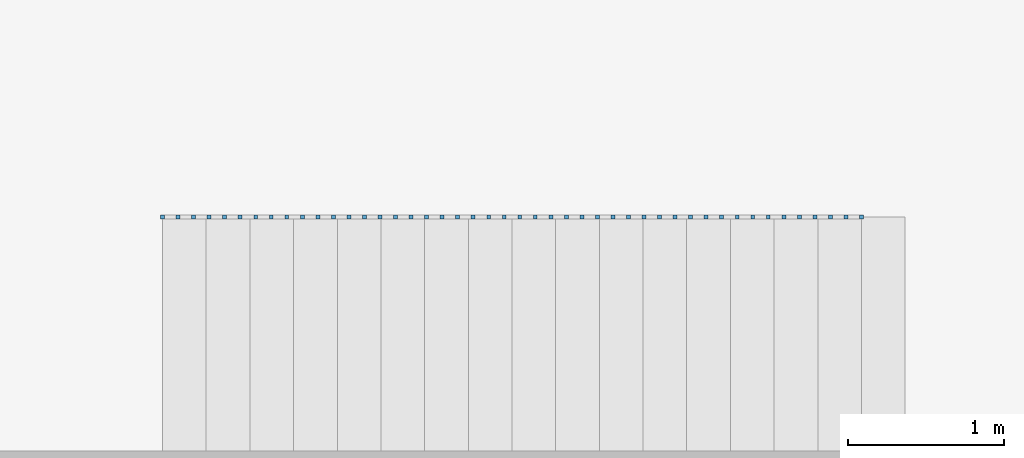
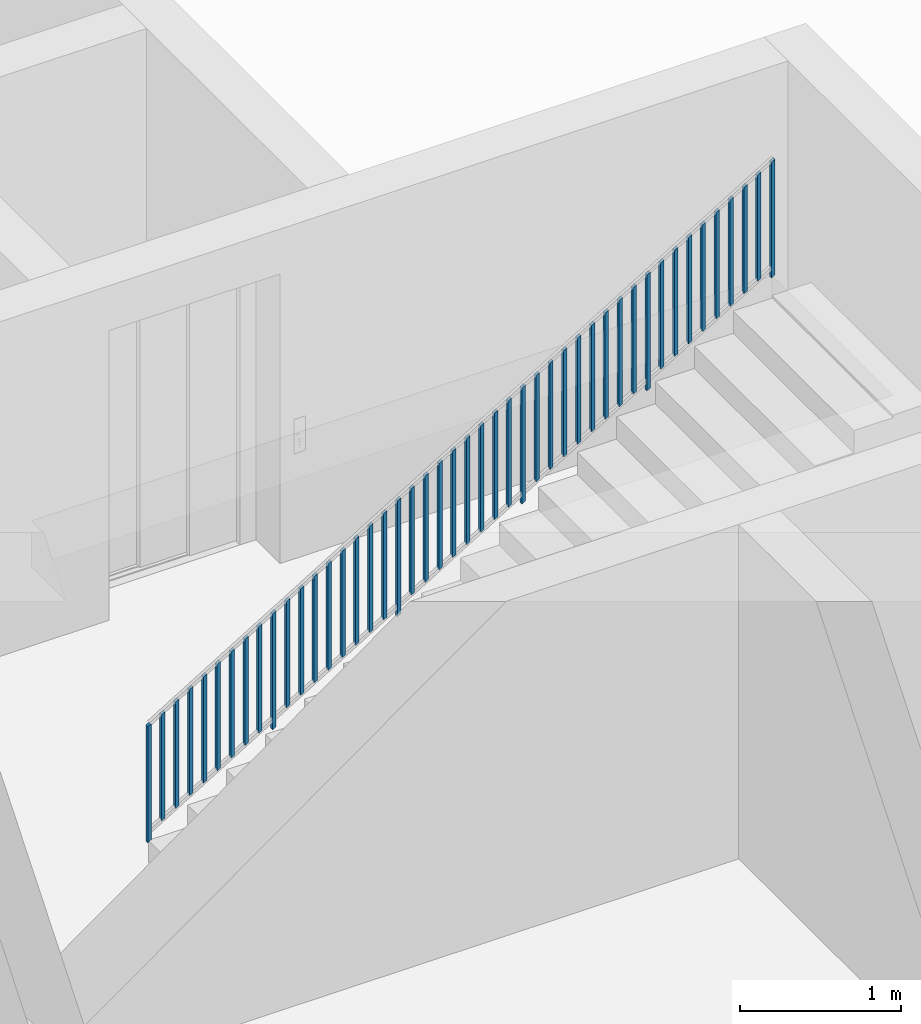
# One storey, part 6 of 6: 46 building element parts, 1 element without a shape of its own.
"""IFC4 building model written with IfcOpenShell, lengths in metres."""

from ifc_helpers import new_model, entity, si_unit, converted_unit, derived_unit, direction, frame, origin_with_axes, place, context, subcontext, project, spatial, polygons, material, type_object, element, aggregate, save


model = new_model("IFC4")

# Units and contexts
model_context = context("Model", 3, precision=1e-05, world=origin_with_axes(), true_north=direction((0.0, 1.0)))
body_context = subcontext(model_context, "Body", "Model", "MODEL_VIEW")
ifc_project = project(units=[si_unit("LENGTHUNIT", "METRE"), si_unit("AREAUNIT", "SQUARE_METRE"), si_unit("VOLUMEUNIT", "CUBIC_METRE"), converted_unit("PLANEANGLEUNIT", "DEGREE", entity("IfcPlaneAngleMeasure", 0.0174532925199), si_unit("PLANEANGLEUNIT", "RADIAN"), dimensions=[0, 0, 0, 0, 0, 0, 0]), converted_unit("TIMEUNIT", "Year", entity("IfcTimeMeasure", 31556926.0), si_unit("TIMEUNIT", "SECOND"), dimensions=[0, 0, 1, 0, 0, 0, 0]), si_unit("MASSUNIT", "GRAM", prefix="KILO"), si_unit("THERMODYNAMICTEMPERATUREUNIT", "DEGREE_CELSIUS"), si_unit("LUMINOUSINTENSITYUNIT", "LUMEN"), si_unit("ENERGYUNIT", "JOULE", prefix="MEGA"), derived_unit("THERMALCONDUCTANCEUNIT", [(si_unit("POWERUNIT", "WATT"), 1), (si_unit("LENGTHUNIT", "METRE"), -1), (si_unit("THERMODYNAMICTEMPERATUREUNIT", "KELVIN"), -1)]), derived_unit("SPECIFICHEATCAPACITYUNIT", [(si_unit("ENERGYUNIT", "JOULE"), 1), (si_unit("MASSUNIT", "GRAM", prefix="KILO"), -1), (si_unit("THERMODYNAMICTEMPERATUREUNIT", "KELVIN"), -1)]), derived_unit("MASSDENSITYUNIT", [(si_unit("MASSUNIT", "GRAM", prefix="KILO"), 1), (si_unit("VOLUMEUNIT", "CUBIC_METRE"), -1)])], contexts=[model_context])

# Site, building, storey, space
site_placement = place(None, origin_with_axes())
site = spatial("IfcSite", under=ifc_project, at=site_placement, CompositionType="ELEMENT")
building_placement = place(site_placement, origin_with_axes())
building = spatial("IfcBuilding", under=site, at=building_placement, CompositionType="ELEMENT")
storey_placement = place(building_placement, frame((0.0, 0.0, -2.89), z_axis=(0.0, 0.0, 1.0), x_axis=(1.0, 0.0, 0.0)))
storey = spatial("IfcBuildingStorey", under=building, at=storey_placement, Name="-1. Geschoss", CompositionType="ELEMENT", Elevation=-2.89)
space_placement = place(storey_placement, frame((-4.9421993804, -2.52881223104, 0.0), z_axis=(0.0, 0.0, 1.0), x_axis=(1.0, 0.0, 0.0)))
space = spatial("IfcSpace", under=storey, at=space_placement, CompositionType="ELEMENT", PredefinedType="INTERNAL")

# Railing, building element parts
railing_type = type_object("IfcRailingType", PredefinedType="NOTDEFINED")
railing_placement = place(space_placement, frame((1.5, 1.5, 0.17), z_axis=(0.0, 0.0, 1.0), x_axis=(1.0, 0.0, 0.0)))
railing = element("IfcRailing", 1, at=railing_placement, inside=space, type_object=railing_type, PredefinedType="NOTDEFINED")
ifc_material = material()
building_element_part_1_placement = place(railing_placement, origin_with_axes())
building_element_part_1 = element("IfcBuildingElementPart", 2, at=building_element_part_1_placement, material=ifc_material, PredefinedType="NOTDEFINED", context=body_context, shape_type="Tessellation", body=[
    polygons([(0.0125, -0.0125, 0.00758928571429), (0.0125, 0.0125, 0.00758928571429), (0.0125, 0.0125, 0.887589285714), (0.0125, -0.0125, 0.887589285714), (-0.0125, -0.0125, -0.00758928571429), (-0.0125, 0.0125, -0.00758928571429), (-0.0125, 0.0125, 0.872410714286), (-0.0125, -0.0125, 0.872410714286)], [[[1, 2, 3, 4]], [[1, 5, 6, 2]], [[2, 6, 7, 3]], [[4, 3, 7, 8]], [[5, 1, 4, 8]], [[6, 5, 8, 7]]], closed=True),
])
building_element_part_2_placement = place(railing_placement, origin_with_axes())
building_element_part_2 = element("IfcBuildingElementPart", 3, at=building_element_part_2_placement, material=ifc_material, PredefinedType="NOTDEFINED", context=body_context, shape_type="Tessellation", body=[
    polygons([(4.4925, -0.0125, 2.72758928571), (4.4925, 0.0125, 2.72758928571), (4.4925, 0.0125, 3.60758928571), (4.4925, -0.0125, 3.60758928571), (4.4675, -0.0125, 2.71241071429), (4.4675, 0.0125, 2.71241071429), (4.4675, 0.0125, 3.59241071429), (4.4675, -0.0125, 3.59241071429)], [[[1, 2, 3, 4]], [[1, 5, 6, 2]], [[2, 6, 7, 3]], [[4, 3, 7, 8]], [[5, 1, 4, 8]], [[6, 5, 8, 7]]], closed=True),
])
building_element_part_3_placement = place(railing_placement, origin_with_axes())
building_element_part_3 = element("IfcBuildingElementPart", 4, at=building_element_part_3_placement, material=ifc_material, PredefinedType="NOTDEFINED", context=body_context, shape_type="Tessellation", body=[
    polygons([(0.112055555556, -0.0125, 0.138033730159), (0.112055555556, 0.0125, 0.138033730159), (0.112055555556, 0.0125, 0.945533730159), (0.112055555556, -0.0125, 0.945533730159), (0.0870555555556, -0.0125, 0.12285515873), (0.0870555555556, 0.0125, 0.12285515873), (0.0870555555556, 0.0125, 0.93035515873), (0.0870555555556, -0.0125, 0.93035515873)], [[[1, 2, 3, 4]], [[1, 5, 6, 2]], [[2, 6, 7, 3]], [[4, 3, 7, 8]], [[5, 1, 4, 8]], [[6, 5, 8, 7]]], closed=True),
])
building_element_part_4_placement = place(railing_placement, origin_with_axes())
building_element_part_4 = element("IfcBuildingElementPart", 5, at=building_element_part_4_placement, material=ifc_material, PredefinedType="NOTDEFINED", context=body_context, shape_type="Tessellation", body=[
    polygons([(0.211611111111, -0.0125, 0.198478174603), (0.211611111111, 0.0125, 0.198478174603), (0.211611111111, 0.0125, 1.0059781746), (0.211611111111, -0.0125, 1.0059781746), (0.186611111111, -0.0125, 0.183299603175), (0.186611111111, 0.0125, 0.183299603175), (0.186611111111, 0.0125, 0.990799603175), (0.186611111111, -0.0125, 0.990799603175)], [[[1, 2, 3, 4]], [[1, 5, 6, 2]], [[2, 6, 7, 3]], [[4, 3, 7, 8]], [[5, 1, 4, 8]], [[6, 5, 8, 7]]], closed=True),
])
building_element_part_5_placement = place(railing_placement, origin_with_axes())
building_element_part_5 = element("IfcBuildingElementPart", 6, at=building_element_part_5_placement, material=ifc_material, PredefinedType="NOTDEFINED", context=body_context, shape_type="Tessellation", body=[
    polygons([(0.311166666667, -0.0125, 0.258922619048), (0.311166666667, 0.0125, 0.258922619048), (0.311166666667, 0.0125, 1.06642261905), (0.311166666667, -0.0125, 1.06642261905), (0.286166666667, -0.0125, 0.243744047619), (0.286166666667, 0.0125, 0.243744047619), (0.286166666667, 0.0125, 1.05124404762), (0.286166666667, -0.0125, 1.05124404762)], [[[1, 2, 3, 4]], [[1, 5, 6, 2]], [[2, 6, 7, 3]], [[4, 3, 7, 8]], [[5, 1, 4, 8]], [[6, 5, 8, 7]]], closed=True),
])
building_element_part_6_placement = place(railing_placement, origin_with_axes())
building_element_part_6 = element("IfcBuildingElementPart", 7, at=building_element_part_6_placement, material=ifc_material, PredefinedType="NOTDEFINED", context=body_context, shape_type="Tessellation", body=[
    polygons([(0.410722222222, -0.0125, 0.319367063492), (0.410722222222, 0.0125, 0.319367063492), (0.410722222222, 0.0125, 1.12686706349), (0.410722222222, -0.0125, 1.12686706349), (0.385722222222, -0.0125, 0.304188492063), (0.385722222222, 0.0125, 0.304188492063), (0.385722222222, 0.0125, 1.11168849206), (0.385722222222, -0.0125, 1.11168849206)], [[[1, 2, 3, 4]], [[1, 5, 6, 2]], [[2, 6, 7, 3]], [[4, 3, 7, 8]], [[5, 1, 4, 8]], [[6, 5, 8, 7]]], closed=True),
])
building_element_part_7_placement = place(railing_placement, origin_with_axes())
building_element_part_7 = element("IfcBuildingElementPart", 8, at=building_element_part_7_placement, material=ifc_material, PredefinedType="NOTDEFINED", context=body_context, shape_type="Tessellation", body=[
    polygons([(0.510277777778, -0.0125, 0.379811507937), (0.510277777778, 0.0125, 0.379811507937), (0.510277777778, 0.0125, 1.18731150794), (0.510277777778, -0.0125, 1.18731150794), (0.485277777778, -0.0125, 0.364632936508), (0.485277777778, 0.0125, 0.364632936508), (0.485277777778, 0.0125, 1.17213293651), (0.485277777778, -0.0125, 1.17213293651)], [[[1, 2, 3, 4]], [[1, 5, 6, 2]], [[2, 6, 7, 3]], [[4, 3, 7, 8]], [[5, 1, 4, 8]], [[6, 5, 8, 7]]], closed=True),
])
building_element_part_8_placement = place(railing_placement, origin_with_axes())
building_element_part_8 = element("IfcBuildingElementPart", 9, at=building_element_part_8_placement, material=ifc_material, PredefinedType="NOTDEFINED", context=body_context, shape_type="Tessellation", body=[
    polygons([(0.609833333333, -0.0125, 0.440255952381), (0.609833333333, 0.0125, 0.440255952381), (0.609833333333, 0.0125, 1.24775595238), (0.609833333333, -0.0125, 1.24775595238), (0.584833333333, -0.0125, 0.425077380952), (0.584833333333, 0.0125, 0.425077380952), (0.584833333333, 0.0125, 1.23257738095), (0.584833333333, -0.0125, 1.23257738095)], [[[1, 2, 3, 4]], [[1, 5, 6, 2]], [[2, 6, 7, 3]], [[4, 3, 7, 8]], [[5, 1, 4, 8]], [[6, 5, 8, 7]]], closed=True),
])
building_element_part_9_placement = place(railing_placement, origin_with_axes())
building_element_part_9 = element("IfcBuildingElementPart", 10, at=building_element_part_9_placement, material=ifc_material, PredefinedType="NOTDEFINED", context=body_context, shape_type="Tessellation", body=[
    polygons([(0.709388888889, -0.0125, 0.500700396825), (0.709388888889, 0.0125, 0.500700396825), (0.709388888889, 0.0125, 1.30820039683), (0.709388888889, -0.0125, 1.30820039683), (0.684388888889, -0.0125, 0.485521825397), (0.684388888889, 0.0125, 0.485521825397), (0.684388888889, 0.0125, 1.2930218254), (0.684388888889, -0.0125, 1.2930218254)], [[[1, 2, 3, 4]], [[1, 5, 6, 2]], [[2, 6, 7, 3]], [[4, 3, 7, 8]], [[5, 1, 4, 8]], [[6, 5, 8, 7]]], closed=True),
])
building_element_part_10_placement = place(railing_placement, origin_with_axes())
building_element_part_10 = element("IfcBuildingElementPart", 11, at=building_element_part_10_placement, material=ifc_material, PredefinedType="NOTDEFINED", context=body_context, shape_type="Tessellation", body=[
    polygons([(0.808944444444, -0.0125, 0.56114484127), (0.808944444444, 0.0125, 0.56114484127), (0.808944444444, 0.0125, 1.36864484127), (0.808944444444, -0.0125, 1.36864484127), (0.783944444444, -0.0125, 0.545966269841), (0.783944444444, 0.0125, 0.545966269841), (0.783944444444, 0.0125, 1.35346626984), (0.783944444444, -0.0125, 1.35346626984)], [[[1, 2, 3, 4]], [[1, 5, 6, 2]], [[2, 6, 7, 3]], [[4, 3, 7, 8]], [[5, 1, 4, 8]], [[6, 5, 8, 7]]], closed=True),
])
building_element_part_11_placement = place(railing_placement, origin_with_axes())
building_element_part_11 = element("IfcBuildingElementPart", 12, at=building_element_part_11_placement, material=ifc_material, PredefinedType="NOTDEFINED", context=body_context, shape_type="Tessellation", body=[
    polygons([(0.9085, -0.0125, 0.551589285714), (0.9085, 0.0125, 0.551589285714), (0.9085, 0.0125, 1.43158928571), (0.9085, -0.0125, 1.43158928571), (0.8835, -0.0125, 0.536410714286), (0.8835, 0.0125, 0.536410714286), (0.8835, 0.0125, 1.41641071429), (0.8835, -0.0125, 1.41641071429)], [[[1, 2, 3, 4]], [[1, 5, 6, 2]], [[2, 6, 7, 3]], [[4, 3, 7, 8]], [[5, 1, 4, 8]], [[6, 5, 8, 7]]], closed=True),
])
building_element_part_12_placement = place(railing_placement, origin_with_axes())
building_element_part_12 = element("IfcBuildingElementPart", 13, at=building_element_part_12_placement, material=ifc_material, PredefinedType="NOTDEFINED", context=body_context, shape_type="Tessellation", body=[
    polygons([(1.00805555556, -0.0125, 0.682033730159), (1.00805555556, 0.0125, 0.682033730159), (1.00805555556, 0.0125, 1.48953373016), (1.00805555556, -0.0125, 1.48953373016), (0.983055555556, -0.0125, 0.66685515873), (0.983055555556, 0.0125, 0.66685515873), (0.983055555556, 0.0125, 1.47435515873), (0.983055555556, -0.0125, 1.47435515873)], [[[1, 2, 3, 4]], [[1, 5, 6, 2]], [[2, 6, 7, 3]], [[4, 3, 7, 8]], [[5, 1, 4, 8]], [[6, 5, 8, 7]]], closed=True),
])
building_element_part_13_placement = place(railing_placement, origin_with_axes())
building_element_part_13 = element("IfcBuildingElementPart", 14, at=building_element_part_13_placement, material=ifc_material, PredefinedType="NOTDEFINED", context=body_context, shape_type="Tessellation", body=[
    polygons([(1.10761111111, -0.0125, 0.742478174603), (1.10761111111, 0.0125, 0.742478174603), (1.10761111111, 0.0125, 1.5499781746), (1.10761111111, -0.0125, 1.5499781746), (1.08261111111, -0.0125, 0.727299603175), (1.08261111111, 0.0125, 0.727299603175), (1.08261111111, 0.0125, 1.53479960317), (1.08261111111, -0.0125, 1.53479960317)], [[[1, 2, 3, 4]], [[1, 5, 6, 2]], [[2, 6, 7, 3]], [[4, 3, 7, 8]], [[5, 1, 4, 8]], [[6, 5, 8, 7]]], closed=True),
])
building_element_part_14_placement = place(railing_placement, origin_with_axes())
building_element_part_14 = element("IfcBuildingElementPart", 15, at=building_element_part_14_placement, material=ifc_material, PredefinedType="NOTDEFINED", context=body_context, shape_type="Tessellation", body=[
    polygons([(1.20716666667, -0.0125, 0.802922619048), (1.20716666667, 0.0125, 0.802922619048), (1.20716666667, 0.0125, 1.61042261905), (1.20716666667, -0.0125, 1.61042261905), (1.18216666667, -0.0125, 0.787744047619), (1.18216666667, 0.0125, 0.787744047619), (1.18216666667, 0.0125, 1.59524404762), (1.18216666667, -0.0125, 1.59524404762)], [[[1, 2, 3, 4]], [[1, 5, 6, 2]], [[2, 6, 7, 3]], [[4, 3, 7, 8]], [[5, 1, 4, 8]], [[6, 5, 8, 7]]], closed=True),
])
building_element_part_15_placement = place(railing_placement, origin_with_axes())
building_element_part_15 = element("IfcBuildingElementPart", 16, at=building_element_part_15_placement, material=ifc_material, PredefinedType="NOTDEFINED", context=body_context, shape_type="Tessellation", body=[
    polygons([(1.30672222222, -0.0125, 0.863367063492), (1.30672222222, 0.0125, 0.863367063492), (1.30672222222, 0.0125, 1.67086706349), (1.30672222222, -0.0125, 1.67086706349), (1.28172222222, -0.0125, 0.848188492063), (1.28172222222, 0.0125, 0.848188492063), (1.28172222222, 0.0125, 1.65568849206), (1.28172222222, -0.0125, 1.65568849206)], [[[1, 2, 3, 4]], [[1, 5, 6, 2]], [[2, 6, 7, 3]], [[4, 3, 7, 8]], [[5, 1, 4, 8]], [[6, 5, 8, 7]]], closed=True),
])
building_element_part_16_placement = place(railing_placement, origin_with_axes())
building_element_part_16 = element("IfcBuildingElementPart", 17, at=building_element_part_16_placement, material=ifc_material, PredefinedType="NOTDEFINED", context=body_context, shape_type="Tessellation", body=[
    polygons([(1.40627777778, -0.0125, 0.923811507937), (1.40627777778, 0.0125, 0.923811507937), (1.40627777778, 0.0125, 1.73131150794), (1.40627777778, -0.0125, 1.73131150794), (1.38127777778, -0.0125, 0.908632936508), (1.38127777778, 0.0125, 0.908632936508), (1.38127777778, 0.0125, 1.71613293651), (1.38127777778, -0.0125, 1.71613293651)], [[[1, 2, 3, 4]], [[1, 5, 6, 2]], [[2, 6, 7, 3]], [[4, 3, 7, 8]], [[5, 1, 4, 8]], [[6, 5, 8, 7]]], closed=True),
])
building_element_part_17_placement = place(railing_placement, origin_with_axes())
building_element_part_17 = element("IfcBuildingElementPart", 18, at=building_element_part_17_placement, material=ifc_material, PredefinedType="NOTDEFINED", context=body_context, shape_type="Tessellation", body=[
    polygons([(1.50583333333, -0.0125, 0.984255952381), (1.50583333333, 0.0125, 0.984255952381), (1.50583333333, 0.0125, 1.79175595238), (1.50583333333, -0.0125, 1.79175595238), (1.48083333333, -0.0125, 0.969077380952), (1.48083333333, 0.0125, 0.969077380952), (1.48083333333, 0.0125, 1.77657738095), (1.48083333333, -0.0125, 1.77657738095)], [[[1, 2, 3, 4]], [[1, 5, 6, 2]], [[2, 6, 7, 3]], [[4, 3, 7, 8]], [[5, 1, 4, 8]], [[6, 5, 8, 7]]], closed=True),
])
building_element_part_18_placement = place(railing_placement, origin_with_axes())
building_element_part_18 = element("IfcBuildingElementPart", 19, at=building_element_part_18_placement, material=ifc_material, PredefinedType="NOTDEFINED", context=body_context, shape_type="Tessellation", body=[
    polygons([(1.60538888889, -0.0125, 1.04470039683), (1.60538888889, 0.0125, 1.04470039683), (1.60538888889, 0.0125, 1.85220039683), (1.60538888889, -0.0125, 1.85220039683), (1.58038888889, -0.0125, 1.0295218254), (1.58038888889, 0.0125, 1.0295218254), (1.58038888889, 0.0125, 1.8370218254), (1.58038888889, -0.0125, 1.8370218254)], [[[1, 2, 3, 4]], [[1, 5, 6, 2]], [[2, 6, 7, 3]], [[4, 3, 7, 8]], [[5, 1, 4, 8]], [[6, 5, 8, 7]]], closed=True),
])
building_element_part_19_placement = place(railing_placement, origin_with_axes())
building_element_part_19 = element("IfcBuildingElementPart", 20, at=building_element_part_19_placement, material=ifc_material, PredefinedType="NOTDEFINED", context=body_context, shape_type="Tessellation", body=[
    polygons([(1.70494444444, -0.0125, 1.10514484127), (1.70494444444, 0.0125, 1.10514484127), (1.70494444444, 0.0125, 1.91264484127), (1.70494444444, -0.0125, 1.91264484127), (1.67994444444, -0.0125, 1.08996626984), (1.67994444444, 0.0125, 1.08996626984), (1.67994444444, 0.0125, 1.89746626984), (1.67994444444, -0.0125, 1.89746626984)], [[[1, 2, 3, 4]], [[1, 5, 6, 2]], [[2, 6, 7, 3]], [[4, 3, 7, 8]], [[5, 1, 4, 8]], [[6, 5, 8, 7]]], closed=True),
])
building_element_part_20_placement = place(railing_placement, origin_with_axes())
building_element_part_20 = element("IfcBuildingElementPart", 21, at=building_element_part_20_placement, material=ifc_material, PredefinedType="NOTDEFINED", context=body_context, shape_type="Tessellation", body=[
    polygons([(1.8045, -0.0125, 1.09558928571), (1.8045, 0.0125, 1.09558928571), (1.8045, 0.0125, 1.97558928571), (1.8045, -0.0125, 1.97558928571), (1.7795, -0.0125, 1.08041071429), (1.7795, 0.0125, 1.08041071429), (1.7795, 0.0125, 1.96041071429), (1.7795, -0.0125, 1.96041071429)], [[[1, 2, 3, 4]], [[1, 5, 6, 2]], [[2, 6, 7, 3]], [[4, 3, 7, 8]], [[5, 1, 4, 8]], [[6, 5, 8, 7]]], closed=True),
])
building_element_part_21_placement = place(railing_placement, origin_with_axes())
building_element_part_21 = element("IfcBuildingElementPart", 22, at=building_element_part_21_placement, material=ifc_material, PredefinedType="NOTDEFINED", context=body_context, shape_type="Tessellation", body=[
    polygons([(1.90405555556, -0.0125, 1.22603373016), (1.90405555556, 0.0125, 1.22603373016), (1.90405555556, 0.0125, 2.03353373016), (1.90405555556, -0.0125, 2.03353373016), (1.87905555556, -0.0125, 1.21085515873), (1.87905555556, 0.0125, 1.21085515873), (1.87905555556, 0.0125, 2.01835515873), (1.87905555556, -0.0125, 2.01835515873)], [[[1, 2, 3, 4]], [[1, 5, 6, 2]], [[2, 6, 7, 3]], [[4, 3, 7, 8]], [[5, 1, 4, 8]], [[6, 5, 8, 7]]], closed=True),
])
building_element_part_22_placement = place(railing_placement, origin_with_axes())
building_element_part_22 = element("IfcBuildingElementPart", 23, at=building_element_part_22_placement, material=ifc_material, PredefinedType="NOTDEFINED", context=body_context, shape_type="Tessellation", body=[
    polygons([(2.00361111111, -0.0125, 1.2864781746), (2.00361111111, 0.0125, 1.2864781746), (2.00361111111, 0.0125, 2.0939781746), (2.00361111111, -0.0125, 2.0939781746), (1.97861111111, -0.0125, 1.27129960317), (1.97861111111, 0.0125, 1.27129960317), (1.97861111111, 0.0125, 2.07879960317), (1.97861111111, -0.0125, 2.07879960317)], [[[1, 2, 3, 4]], [[1, 5, 6, 2]], [[2, 6, 7, 3]], [[4, 3, 7, 8]], [[5, 1, 4, 8]], [[6, 5, 8, 7]]], closed=True),
])
building_element_part_23_placement = place(railing_placement, origin_with_axes())
building_element_part_23 = element("IfcBuildingElementPart", 24, at=building_element_part_23_placement, material=ifc_material, PredefinedType="NOTDEFINED", context=body_context, shape_type="Tessellation", body=[
    polygons([(2.10316666667, -0.0125, 1.34692261905), (2.10316666667, 0.0125, 1.34692261905), (2.10316666667, 0.0125, 2.15442261905), (2.10316666667, -0.0125, 2.15442261905), (2.07816666667, -0.0125, 1.33174404762), (2.07816666667, 0.0125, 1.33174404762), (2.07816666667, 0.0125, 2.13924404762), (2.07816666667, -0.0125, 2.13924404762)], [[[1, 2, 3, 4]], [[1, 5, 6, 2]], [[2, 6, 7, 3]], [[4, 3, 7, 8]], [[5, 1, 4, 8]], [[6, 5, 8, 7]]], closed=True),
])
building_element_part_24_placement = place(railing_placement, origin_with_axes())
building_element_part_24 = element("IfcBuildingElementPart", 25, at=building_element_part_24_placement, material=ifc_material, PredefinedType="NOTDEFINED", context=body_context, shape_type="Tessellation", body=[
    polygons([(2.20272222222, -0.0125, 1.40736706349), (2.20272222222, 0.0125, 1.40736706349), (2.20272222222, 0.0125, 2.21486706349), (2.20272222222, -0.0125, 2.21486706349), (2.17772222222, -0.0125, 1.39218849206), (2.17772222222, 0.0125, 1.39218849206), (2.17772222222, 0.0125, 2.19968849206), (2.17772222222, -0.0125, 2.19968849206)], [[[1, 2, 3, 4]], [[1, 5, 6, 2]], [[2, 6, 7, 3]], [[4, 3, 7, 8]], [[5, 1, 4, 8]], [[6, 5, 8, 7]]], closed=True),
])
building_element_part_25_placement = place(railing_placement, origin_with_axes())
building_element_part_25 = element("IfcBuildingElementPart", 26, at=building_element_part_25_placement, material=ifc_material, PredefinedType="NOTDEFINED", context=body_context, shape_type="Tessellation", body=[
    polygons([(2.30227777778, -0.0125, 1.46781150794), (2.30227777778, 0.0125, 1.46781150794), (2.30227777778, 0.0125, 2.27531150794), (2.30227777778, -0.0125, 2.27531150794), (2.27727777778, -0.0125, 1.45263293651), (2.27727777778, 0.0125, 1.45263293651), (2.27727777778, 0.0125, 2.26013293651), (2.27727777778, -0.0125, 2.26013293651)], [[[1, 2, 3, 4]], [[1, 5, 6, 2]], [[2, 6, 7, 3]], [[4, 3, 7, 8]], [[5, 1, 4, 8]], [[6, 5, 8, 7]]], closed=True),
])
building_element_part_26_placement = place(railing_placement, origin_with_axes())
building_element_part_26 = element("IfcBuildingElementPart", 27, at=building_element_part_26_placement, material=ifc_material, PredefinedType="NOTDEFINED", context=body_context, shape_type="Tessellation", body=[
    polygons([(2.40183333333, -0.0125, 1.52825595238), (2.40183333333, 0.0125, 1.52825595238), (2.40183333333, 0.0125, 2.33575595238), (2.40183333333, -0.0125, 2.33575595238), (2.37683333333, -0.0125, 1.51307738095), (2.37683333333, 0.0125, 1.51307738095), (2.37683333333, 0.0125, 2.32057738095), (2.37683333333, -0.0125, 2.32057738095)], [[[1, 2, 3, 4]], [[1, 5, 6, 2]], [[2, 6, 7, 3]], [[4, 3, 7, 8]], [[5, 1, 4, 8]], [[6, 5, 8, 7]]], closed=True),
])
building_element_part_27_placement = place(railing_placement, origin_with_axes())
building_element_part_27 = element("IfcBuildingElementPart", 28, at=building_element_part_27_placement, material=ifc_material, PredefinedType="NOTDEFINED", context=body_context, shape_type="Tessellation", body=[
    polygons([(2.50138888889, -0.0125, 1.58870039683), (2.50138888889, 0.0125, 1.58870039683), (2.50138888889, 0.0125, 2.39620039683), (2.50138888889, -0.0125, 2.39620039683), (2.47638888889, -0.0125, 1.5735218254), (2.47638888889, 0.0125, 1.5735218254), (2.47638888889, 0.0125, 2.3810218254), (2.47638888889, -0.0125, 2.3810218254)], [[[1, 2, 3, 4]], [[1, 5, 6, 2]], [[2, 6, 7, 3]], [[4, 3, 7, 8]], [[5, 1, 4, 8]], [[6, 5, 8, 7]]], closed=True),
])
building_element_part_28_placement = place(railing_placement, origin_with_axes())
building_element_part_28 = element("IfcBuildingElementPart", 29, at=building_element_part_28_placement, material=ifc_material, PredefinedType="NOTDEFINED", context=body_context, shape_type="Tessellation", body=[
    polygons([(2.60094444444, -0.0125, 1.64914484127), (2.60094444444, 0.0125, 1.64914484127), (2.60094444444, 0.0125, 2.45664484127), (2.60094444444, -0.0125, 2.45664484127), (2.57594444444, -0.0125, 1.63396626984), (2.57594444444, 0.0125, 1.63396626984), (2.57594444444, 0.0125, 2.44146626984), (2.57594444444, -0.0125, 2.44146626984)], [[[1, 2, 3, 4]], [[1, 5, 6, 2]], [[2, 6, 7, 3]], [[4, 3, 7, 8]], [[5, 1, 4, 8]], [[6, 5, 8, 7]]], closed=True),
])
building_element_part_29_placement = place(railing_placement, origin_with_axes())
building_element_part_29 = element("IfcBuildingElementPart", 30, at=building_element_part_29_placement, material=ifc_material, PredefinedType="NOTDEFINED", context=body_context, shape_type="Tessellation", body=[
    polygons([(2.7005, -0.0125, 1.63958928571), (2.7005, 0.0125, 1.63958928571), (2.7005, 0.0125, 2.51958928571), (2.7005, -0.0125, 2.51958928571), (2.6755, -0.0125, 1.62441071429), (2.6755, 0.0125, 1.62441071429), (2.6755, 0.0125, 2.50441071429), (2.6755, -0.0125, 2.50441071429)], [[[1, 2, 3, 4]], [[1, 5, 6, 2]], [[2, 6, 7, 3]], [[4, 3, 7, 8]], [[5, 1, 4, 8]], [[6, 5, 8, 7]]], closed=True),
])
building_element_part_30_placement = place(railing_placement, origin_with_axes())
building_element_part_30 = element("IfcBuildingElementPart", 31, at=building_element_part_30_placement, material=ifc_material, PredefinedType="NOTDEFINED", context=body_context, shape_type="Tessellation", body=[
    polygons([(2.80005555556, -0.0125, 1.77003373016), (2.80005555556, 0.0125, 1.77003373016), (2.80005555556, 0.0125, 2.57753373016), (2.80005555556, -0.0125, 2.57753373016), (2.77505555556, -0.0125, 1.75485515873), (2.77505555556, 0.0125, 1.75485515873), (2.77505555556, 0.0125, 2.56235515873), (2.77505555556, -0.0125, 2.56235515873)], [[[1, 2, 3, 4]], [[1, 5, 6, 2]], [[2, 6, 7, 3]], [[4, 3, 7, 8]], [[5, 1, 4, 8]], [[6, 5, 8, 7]]], closed=True),
])
building_element_part_31_placement = place(railing_placement, origin_with_axes())
building_element_part_31 = element("IfcBuildingElementPart", 32, at=building_element_part_31_placement, material=ifc_material, PredefinedType="NOTDEFINED", context=body_context, shape_type="Tessellation", body=[
    polygons([(2.89961111111, -0.0125, 1.8304781746), (2.89961111111, 0.0125, 1.8304781746), (2.89961111111, 0.0125, 2.6379781746), (2.89961111111, -0.0125, 2.6379781746), (2.87461111111, -0.0125, 1.81529960317), (2.87461111111, 0.0125, 1.81529960317), (2.87461111111, 0.0125, 2.62279960317), (2.87461111111, -0.0125, 2.62279960317)], [[[1, 2, 3, 4]], [[1, 5, 6, 2]], [[2, 6, 7, 3]], [[4, 3, 7, 8]], [[5, 1, 4, 8]], [[6, 5, 8, 7]]], closed=True),
])
building_element_part_32_placement = place(railing_placement, origin_with_axes())
building_element_part_32 = element("IfcBuildingElementPart", 33, at=building_element_part_32_placement, material=ifc_material, PredefinedType="NOTDEFINED", context=body_context, shape_type="Tessellation", body=[
    polygons([(2.99916666667, -0.0125, 1.89092261905), (2.99916666667, 0.0125, 1.89092261905), (2.99916666667, 0.0125, 2.69842261905), (2.99916666667, -0.0125, 2.69842261905), (2.97416666667, -0.0125, 1.87574404762), (2.97416666667, 0.0125, 1.87574404762), (2.97416666667, 0.0125, 2.68324404762), (2.97416666667, -0.0125, 2.68324404762)], [[[1, 2, 3, 4]], [[1, 5, 6, 2]], [[2, 6, 7, 3]], [[4, 3, 7, 8]], [[5, 1, 4, 8]], [[6, 5, 8, 7]]], closed=True),
])
building_element_part_33_placement = place(railing_placement, origin_with_axes())
building_element_part_33 = element("IfcBuildingElementPart", 34, at=building_element_part_33_placement, material=ifc_material, PredefinedType="NOTDEFINED", context=body_context, shape_type="Tessellation", body=[
    polygons([(3.09872222222, -0.0125, 1.95136706349), (3.09872222222, 0.0125, 1.95136706349), (3.09872222222, 0.0125, 2.75886706349), (3.09872222222, -0.0125, 2.75886706349), (3.07372222222, -0.0125, 1.93618849206), (3.07372222222, 0.0125, 1.93618849206), (3.07372222222, 0.0125, 2.74368849206), (3.07372222222, -0.0125, 2.74368849206)], [[[1, 2, 3, 4]], [[1, 5, 6, 2]], [[2, 6, 7, 3]], [[4, 3, 7, 8]], [[5, 1, 4, 8]], [[6, 5, 8, 7]]], closed=True),
])
building_element_part_34_placement = place(railing_placement, origin_with_axes())
building_element_part_34 = element("IfcBuildingElementPart", 35, at=building_element_part_34_placement, material=ifc_material, PredefinedType="NOTDEFINED", context=body_context, shape_type="Tessellation", body=[
    polygons([(3.19827777778, -0.0125, 2.01181150794), (3.19827777778, 0.0125, 2.01181150794), (3.19827777778, 0.0125, 2.81931150794), (3.19827777778, -0.0125, 2.81931150794), (3.17327777778, -0.0125, 1.99663293651), (3.17327777778, 0.0125, 1.99663293651), (3.17327777778, 0.0125, 2.80413293651), (3.17327777778, -0.0125, 2.80413293651)], [[[1, 2, 3, 4]], [[1, 5, 6, 2]], [[2, 6, 7, 3]], [[4, 3, 7, 8]], [[5, 1, 4, 8]], [[6, 5, 8, 7]]], closed=True),
])
building_element_part_35_placement = place(railing_placement, origin_with_axes())
building_element_part_35 = element("IfcBuildingElementPart", 36, at=building_element_part_35_placement, material=ifc_material, PredefinedType="NOTDEFINED", context=body_context, shape_type="Tessellation", body=[
    polygons([(3.29783333333, -0.0125, 2.07225595238), (3.29783333333, 0.0125, 2.07225595238), (3.29783333333, 0.0125, 2.87975595238), (3.29783333333, -0.0125, 2.87975595238), (3.27283333333, -0.0125, 2.05707738095), (3.27283333333, 0.0125, 2.05707738095), (3.27283333333, 0.0125, 2.86457738095), (3.27283333333, -0.0125, 2.86457738095)], [[[1, 2, 3, 4]], [[1, 5, 6, 2]], [[2, 6, 7, 3]], [[4, 3, 7, 8]], [[5, 1, 4, 8]], [[6, 5, 8, 7]]], closed=True),
])
building_element_part_36_placement = place(railing_placement, origin_with_axes())
building_element_part_36 = element("IfcBuildingElementPart", 37, at=building_element_part_36_placement, material=ifc_material, PredefinedType="NOTDEFINED", context=body_context, shape_type="Tessellation", body=[
    polygons([(3.39738888889, -0.0125, 2.13270039683), (3.39738888889, 0.0125, 2.13270039683), (3.39738888889, 0.0125, 2.94020039683), (3.39738888889, -0.0125, 2.94020039683), (3.37238888889, -0.0125, 2.1175218254), (3.37238888889, 0.0125, 2.1175218254), (3.37238888889, 0.0125, 2.9250218254), (3.37238888889, -0.0125, 2.9250218254)], [[[1, 2, 3, 4]], [[1, 5, 6, 2]], [[2, 6, 7, 3]], [[4, 3, 7, 8]], [[5, 1, 4, 8]], [[6, 5, 8, 7]]], closed=True),
])
building_element_part_37_placement = place(railing_placement, origin_with_axes())
building_element_part_37 = element("IfcBuildingElementPart", 38, at=building_element_part_37_placement, material=ifc_material, PredefinedType="NOTDEFINED", context=body_context, shape_type="Tessellation", body=[
    polygons([(3.49694444444, -0.0125, 2.19314484127), (3.49694444444, 0.0125, 2.19314484127), (3.49694444444, 0.0125, 3.00064484127), (3.49694444444, -0.0125, 3.00064484127), (3.47194444444, -0.0125, 2.17796626984), (3.47194444444, 0.0125, 2.17796626984), (3.47194444444, 0.0125, 2.98546626984), (3.47194444444, -0.0125, 2.98546626984)], [[[1, 2, 3, 4]], [[1, 5, 6, 2]], [[2, 6, 7, 3]], [[4, 3, 7, 8]], [[5, 1, 4, 8]], [[6, 5, 8, 7]]], closed=True),
])
building_element_part_38_placement = place(railing_placement, origin_with_axes())
building_element_part_38 = element("IfcBuildingElementPart", 39, at=building_element_part_38_placement, material=ifc_material, PredefinedType="NOTDEFINED", context=body_context, shape_type="Tessellation", body=[
    polygons([(3.5965, -0.0125, 2.18358928571), (3.5965, 0.0125, 2.18358928571), (3.5965, 0.0125, 3.06358928571), (3.5965, -0.0125, 3.06358928571), (3.5715, -0.0125, 2.16841071429), (3.5715, 0.0125, 2.16841071429), (3.5715, 0.0125, 3.04841071429), (3.5715, -0.0125, 3.04841071429)], [[[1, 2, 3, 4]], [[1, 5, 6, 2]], [[2, 6, 7, 3]], [[4, 3, 7, 8]], [[5, 1, 4, 8]], [[6, 5, 8, 7]]], closed=True),
])
building_element_part_39_placement = place(railing_placement, origin_with_axes())
building_element_part_39 = element("IfcBuildingElementPart", 40, at=building_element_part_39_placement, material=ifc_material, PredefinedType="NOTDEFINED", context=body_context, shape_type="Tessellation", body=[
    polygons([(3.69605555556, -0.0125, 2.31403373016), (3.69605555556, 0.0125, 2.31403373016), (3.69605555556, 0.0125, 3.12153373016), (3.69605555556, -0.0125, 3.12153373016), (3.67105555556, -0.0125, 2.29885515873), (3.67105555556, 0.0125, 2.29885515873), (3.67105555556, 0.0125, 3.10635515873), (3.67105555556, -0.0125, 3.10635515873)], [[[1, 2, 3, 4]], [[1, 5, 6, 2]], [[2, 6, 7, 3]], [[4, 3, 7, 8]], [[5, 1, 4, 8]], [[6, 5, 8, 7]]], closed=True),
])
building_element_part_40_placement = place(railing_placement, origin_with_axes())
building_element_part_40 = element("IfcBuildingElementPart", 41, at=building_element_part_40_placement, material=ifc_material, PredefinedType="NOTDEFINED", context=body_context, shape_type="Tessellation", body=[
    polygons([(3.79561111111, -0.0125, 2.3744781746), (3.79561111111, 0.0125, 2.3744781746), (3.79561111111, 0.0125, 3.1819781746), (3.79561111111, -0.0125, 3.1819781746), (3.77061111111, -0.0125, 2.35929960317), (3.77061111111, 0.0125, 2.35929960317), (3.77061111111, 0.0125, 3.16679960317), (3.77061111111, -0.0125, 3.16679960317)], [[[1, 2, 3, 4]], [[1, 5, 6, 2]], [[2, 6, 7, 3]], [[4, 3, 7, 8]], [[5, 1, 4, 8]], [[6, 5, 8, 7]]], closed=True),
])
building_element_part_41_placement = place(railing_placement, origin_with_axes())
building_element_part_41 = element("IfcBuildingElementPart", 42, at=building_element_part_41_placement, material=ifc_material, PredefinedType="NOTDEFINED", context=body_context, shape_type="Tessellation", body=[
    polygons([(3.89516666667, -0.0125, 2.43492261905), (3.89516666667, 0.0125, 2.43492261905), (3.89516666667, 0.0125, 3.24242261905), (3.89516666667, -0.0125, 3.24242261905), (3.87016666667, -0.0125, 2.41974404762), (3.87016666667, 0.0125, 2.41974404762), (3.87016666667, 0.0125, 3.22724404762), (3.87016666667, -0.0125, 3.22724404762)], [[[1, 2, 3, 4]], [[1, 5, 6, 2]], [[2, 6, 7, 3]], [[4, 3, 7, 8]], [[5, 1, 4, 8]], [[6, 5, 8, 7]]], closed=True),
])
building_element_part_42_placement = place(railing_placement, origin_with_axes())
building_element_part_42 = element("IfcBuildingElementPart", 43, at=building_element_part_42_placement, material=ifc_material, PredefinedType="NOTDEFINED", context=body_context, shape_type="Tessellation", body=[
    polygons([(3.99472222222, -0.0125, 2.49536706349), (3.99472222222, 0.0125, 2.49536706349), (3.99472222222, 0.0125, 3.30286706349), (3.99472222222, -0.0125, 3.30286706349), (3.96972222222, -0.0125, 2.48018849206), (3.96972222222, 0.0125, 2.48018849206), (3.96972222222, 0.0125, 3.28768849206), (3.96972222222, -0.0125, 3.28768849206)], [[[1, 2, 3, 4]], [[1, 5, 6, 2]], [[2, 6, 7, 3]], [[4, 3, 7, 8]], [[5, 1, 4, 8]], [[6, 5, 8, 7]]], closed=True),
])
building_element_part_43_placement = place(railing_placement, origin_with_axes())
building_element_part_43 = element("IfcBuildingElementPart", 44, at=building_element_part_43_placement, material=ifc_material, PredefinedType="NOTDEFINED", context=body_context, shape_type="Tessellation", body=[
    polygons([(4.09427777778, -0.0125, 2.55581150794), (4.09427777778, 0.0125, 2.55581150794), (4.09427777778, 0.0125, 3.36331150794), (4.09427777778, -0.0125, 3.36331150794), (4.06927777778, -0.0125, 2.54063293651), (4.06927777778, 0.0125, 2.54063293651), (4.06927777778, 0.0125, 3.34813293651), (4.06927777778, -0.0125, 3.34813293651)], [[[1, 2, 3, 4]], [[1, 5, 6, 2]], [[2, 6, 7, 3]], [[4, 3, 7, 8]], [[5, 1, 4, 8]], [[6, 5, 8, 7]]], closed=True),
])
building_element_part_44_placement = place(railing_placement, origin_with_axes())
building_element_part_44 = element("IfcBuildingElementPart", 45, at=building_element_part_44_placement, material=ifc_material, PredefinedType="NOTDEFINED", context=body_context, shape_type="Tessellation", body=[
    polygons([(4.19383333333, -0.0125, 2.61625595238), (4.19383333333, 0.0125, 2.61625595238), (4.19383333333, 0.0125, 3.42375595238), (4.19383333333, -0.0125, 3.42375595238), (4.16883333333, -0.0125, 2.60107738095), (4.16883333333, 0.0125, 2.60107738095), (4.16883333333, 0.0125, 3.40857738095), (4.16883333333, -0.0125, 3.40857738095)], [[[1, 2, 3, 4]], [[1, 5, 6, 2]], [[2, 6, 7, 3]], [[4, 3, 7, 8]], [[5, 1, 4, 8]], [[6, 5, 8, 7]]], closed=True),
])
building_element_part_45_placement = place(railing_placement, origin_with_axes())
building_element_part_45 = element("IfcBuildingElementPart", 46, at=building_element_part_45_placement, material=ifc_material, PredefinedType="NOTDEFINED", context=body_context, shape_type="Tessellation", body=[
    polygons([(4.29338888889, -0.0125, 2.67670039683), (4.29338888889, 0.0125, 2.67670039683), (4.29338888889, 0.0125, 3.48420039683), (4.29338888889, -0.0125, 3.48420039683), (4.26838888889, -0.0125, 2.6615218254), (4.26838888889, 0.0125, 2.6615218254), (4.26838888889, 0.0125, 3.4690218254), (4.26838888889, -0.0125, 3.4690218254)], [[[1, 2, 3, 4]], [[1, 5, 6, 2]], [[2, 6, 7, 3]], [[4, 3, 7, 8]], [[5, 1, 4, 8]], [[6, 5, 8, 7]]], closed=True),
])
building_element_part_46_placement = place(railing_placement, origin_with_axes())
building_element_part_46 = element("IfcBuildingElementPart", 47, at=building_element_part_46_placement, material=ifc_material, PredefinedType="NOTDEFINED", context=body_context, shape_type="Tessellation", body=[
    polygons([(4.39294444444, -0.0125, 2.73714484127), (4.39294444444, 0.0125, 2.73714484127), (4.39294444444, 0.0125, 3.54464484127), (4.39294444444, -0.0125, 3.54464484127), (4.36794444444, -0.0125, 2.72196626984), (4.36794444444, 0.0125, 2.72196626984), (4.36794444444, 0.0125, 3.52946626984), (4.36794444444, -0.0125, 3.52946626984)], [[[1, 2, 3, 4]], [[1, 5, 6, 2]], [[2, 6, 7, 3]], [[4, 3, 7, 8]], [[5, 1, 4, 8]], [[6, 5, 8, 7]]], closed=True),
])
aggregate(railing, [building_element_part_1, building_element_part_2, building_element_part_3, building_element_part_4, building_element_part_5, building_element_part_6, building_element_part_7, building_element_part_8, building_element_part_9, building_element_part_10, building_element_part_11, building_element_part_12, building_element_part_13, building_element_part_14, building_element_part_15, building_element_part_16, building_element_part_17, building_element_part_18, building_element_part_19, building_element_part_20, building_element_part_21, building_element_part_22, building_element_part_23, building_element_part_24, building_element_part_25, building_element_part_26, building_element_part_27, building_element_part_28, building_element_part_29, building_element_part_30, building_element_part_31, building_element_part_32, building_element_part_33, building_element_part_34, building_element_part_35, building_element_part_36, building_element_part_37, building_element_part_38, building_element_part_39, building_element_part_40, building_element_part_41, building_element_part_42, building_element_part_43, building_element_part_44, building_element_part_45, building_element_part_46])

save(model, "model.ifc")
